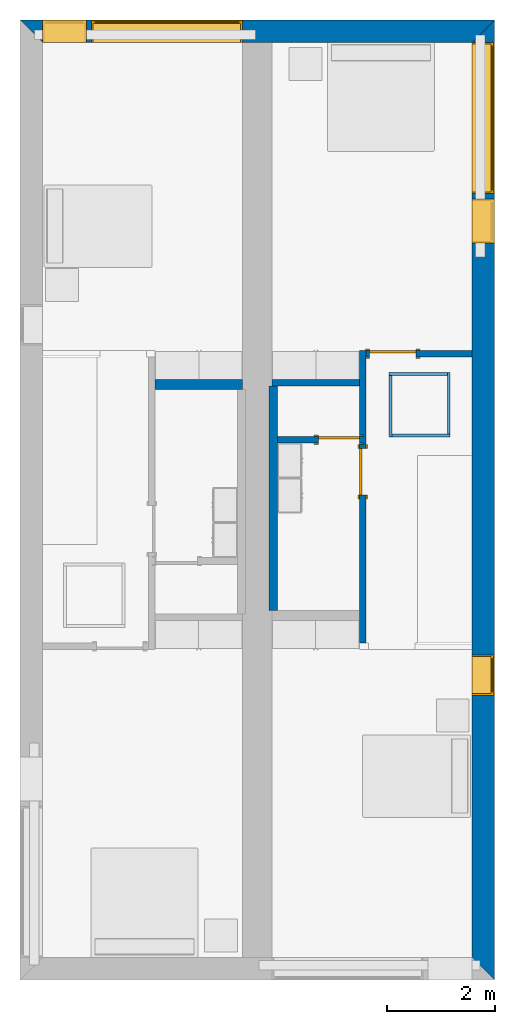
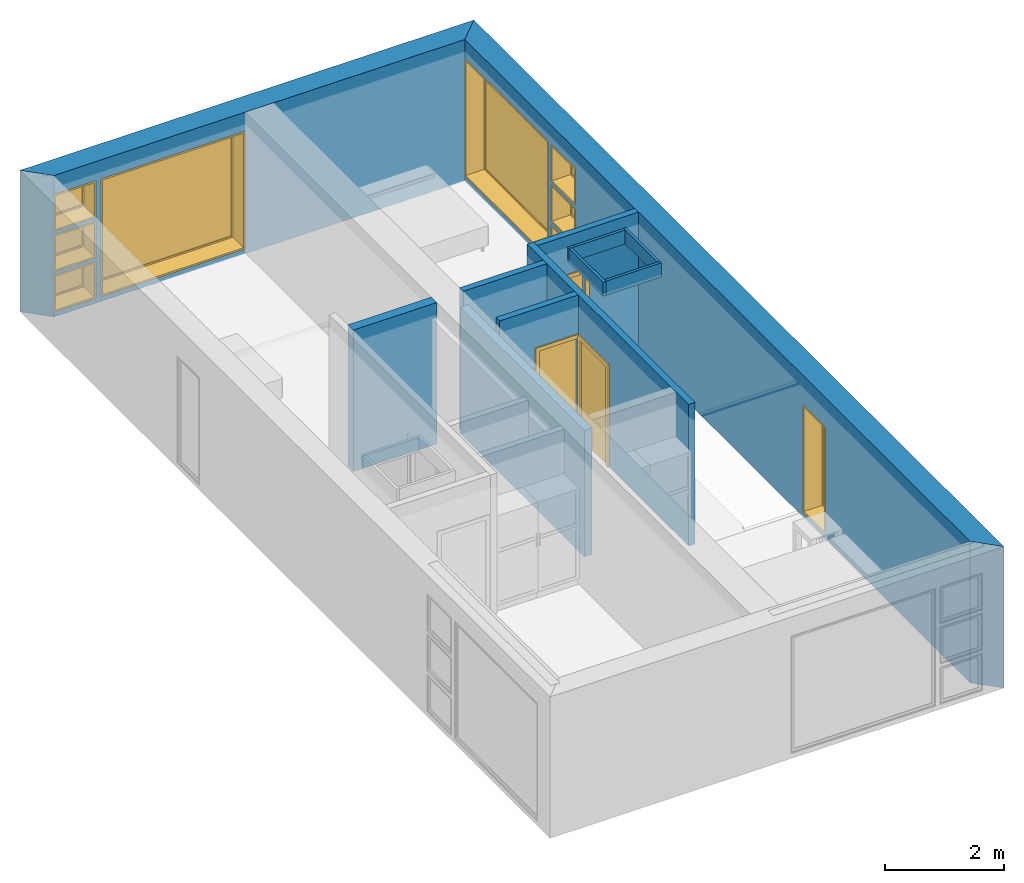
# One storey, part 3 of 12: 12 walls, 9 windows, 3 doors, 12 openings.
"""IFC2X3 building model written with IfcOpenShell, lengths in metres."""

from ifc_helpers import new_model, entity, si_unit, converted_unit, frame, frame_2d, origin, origin_2d_with_axis, place, context, project, spatial, polyline, rectangle, outline, extrude, source, transform, mapped, material, layer, layer_set, layer_usage, type_object, type_shapes, element, fill, save


model = new_model("IFC2X3")

# Units and contexts
model_context = context("Model", 3, precision=1e-09, world=origin())
plan_context = context("Plan", 3, precision=1e-09, world=origin())
ifc_project = project(units=[si_unit("LENGTHUNIT", "METRE"), si_unit("AREAUNIT", "SQUARE_METRE"), si_unit("VOLUMEUNIT", "CUBIC_METRE"), converted_unit("PLANEANGLEUNIT", "DEGREE", entity("IfcRatioMeasure", 0.0174532925199433), si_unit("PLANEANGLEUNIT", "RADIAN"), dimensions=[0, 0, 0, 0, 0, 0, 0]), si_unit("TIMEUNIT", "SECOND")], contexts=[model_context, plan_context])

# Site, building, storey
site_placement = place(None, origin())
site = spatial("IfcSite", under=ifc_project, at=site_placement, CompositionType="ELEMENT")
building_placement = place(site_placement, origin())
building = spatial("IfcBuilding", under=site, at=building_placement, CompositionType="ELEMENT")
storey_placement = place(building_placement, frame((0.0, 0.0, 3.10000000000038)))
storey = spatial("IfcBuildingStorey", under=building, at=storey_placement, Name="Level 2", CompositionType="ELEMENT", Elevation=3.10000000000038)

# Wall, openings, windows
ifc_material_1 = material(Name="Masonry - Brick")
ifc_layer_1 = layer(ifc_material_1, 0.092)
ifc_material_2 = material(Name="Misc. Air Layers - Air Space")
ifc_layer_2 = layer(ifc_material_2, 0.025)
ifc_material_3 = material(Name="Insulation / Thermal Barriers - Rigid insulation")
ifc_layer_3 = layer(ifc_material_3, 0.05)
ifc_material_4 = material(Name="Masonry - Concrete Block")
ifc_layer_4 = layer(ifc_material_4, 0.193)
ifc_material_5 = material(Name="Metal - Stud Layer")
ifc_layer_5 = layer(ifc_material_5, 0.041)
ifc_material_6 = material(Name="Plasterboard")
ifc_layer_6 = layer(ifc_material_6, 0.016)
ifc_layer_set_1 = layer_set([ifc_layer_1, ifc_layer_2, ifc_layer_3, ifc_layer_4, ifc_layer_5, ifc_layer_6], Name="Basic Wall:Exterior - Brick on Block")
ifc_layer_usage_1 = layer_usage(ifc_layer_set_1, "AXIS2", "NEGATIVE", 0.2085)
wall_1_placement = place(storey_placement, frame((0.0, -0.2085, 0.0)))
wall_1 = element("IfcWallStandardCase", 1, at=wall_1_placement, inside=storey, material=ifc_layer_usage_1, Name="Basic Wall:Exterior - Brick on Block", ObjectType="Basic Wall:Exterior - Brick on Block", context=model_context, shape_type="SweptSolid", body=[
    extrude(outline(polyline([(8.383, -0.2085), (8.8, 0.2085), (0.0, 0.2085), (0.417000000000001, -0.2085), (4.125, -0.2085), (4.675, -0.2085), (8.383, -0.2085)])), origin(), (0.0, 0.0, 1.0), 2.90000000000001),
])
opening_1_placement = place(wall_1_placement, frame((1.325, -0.2085, 0.0999999999998186)))
opening_1 = element("IfcOpeningElement", 2, at=opening_1_placement, cuts=wall_1, ObjectType="Opening", context=model_context, shape_type="SweptSolid", body=[
    extrude(rectangle(XDim=2.41, YDim=2.8, at=frame_2d((1.205, 1.4), x_axis=(1.0, 0.0))), frame((0.0, 0.0, 0.0), z_axis=(0.0, 1.0, 0.0), x_axis=(0.0, 0.0, 1.0)), (0.0, 0.0, 1.0), 0.417),
])
opening_2_placement = place(wall_1_placement, frame((0.417, -0.2085, 0.0999999999998235)))
opening_2 = element("IfcOpeningElement", 3, at=opening_2_placement, cuts=wall_1, ObjectType="Opening", context=model_context, shape_type="SweptSolid", body=[
    extrude(rectangle(XDim=0.758999999999998, YDim=0.819, at=frame_2d((0.379499999999999, 0.4095), x_axis=(1.0, 0.0))), frame((0.0, 0.0, 0.0), z_axis=(0.0, 1.0, 0.0), x_axis=(0.0, 0.0, 1.0)), (0.0, 0.0, 1.0), 0.417),
])
opening_3_placement = place(wall_1_placement, frame((0.417000000000015, -0.208500000000001, 0.925499999999817)))
opening_3 = element("IfcOpeningElement", 4, at=opening_3_placement, cuts=wall_1, ObjectType="Opening", context=model_context, shape_type="SweptSolid", body=[
    extrude(rectangle(XDim=0.759000000000001, YDim=0.819, at=frame_2d((0.3795, 0.4095), x_axis=(-1.0, 0.0))), frame((0.0, 0.0, 0.0), z_axis=(0.0, 1.0, 0.0), x_axis=(0.0, 0.0, 1.0)), (0.0, 0.0, 1.0), 0.417),
])
opening_4_placement = place(wall_1_placement, frame((0.417, -0.2085, 1.75099999999982)))
opening_4 = element("IfcOpeningElement", 5, at=opening_4_placement, cuts=wall_1, ObjectType="Opening", context=model_context, shape_type="SweptSolid", body=[
    extrude(rectangle(XDim=0.758999999999998, YDim=0.819, at=frame_2d((0.379499999999999, 0.4095), x_axis=(1.0, 0.0))), frame((0.0, 0.0, 0.0), z_axis=(0.0, 1.0, 0.0), x_axis=(0.0, 0.0, 1.0)), (0.0, 0.0, 1.0), 0.417),
])
window_style_1 = type_object("IfcWindowStyle", Name="2800mm x 2410mm", ConstructionType="NOTDEFINED", OperationType="NOTDEFINED", ParameterTakesPrecedence=False, Sizeable=False)
shared_shape_1 = source(origin(), model_context, "Body", "SweptSolid", [
    extrude(rectangle(XDim=0.012, YDim=2.674, at=origin_2d_with_axis()), frame((1.40000000000001, 0.375999999999996, 0.0629999999999851), z_axis=(0.0, 0.0, 1.0), x_axis=(0.0, -1.0, 0.0)), (0.0, 0.0, 1.0), 2.28400000000001),
    extrude(outline(polyline([(-1.381, -1.186), (1.381, -1.186), (1.381, 1.186), (-1.381, 1.186), (-1.381, -1.186)]), holes=[polyline([(-1.337, -1.142), (-1.337, 1.142), (1.337, 1.142), (1.337, -1.142), (-1.337, -1.142)])]), frame((1.40000000000001, 0.353999999999968, 1.20499999999999), z_axis=(0.0, 1.0, 0.0), x_axis=(1.0, 0.0, 0.0)), (0.0, 0.0, 1.0), 0.0440000000000274),
    extrude(outline(polyline([(-1.4, -1.205), (1.4, -1.205), (1.4, 1.205), (-1.4, 1.205), (-1.4, -1.205)]), holes=[polyline([(-1.381, -1.18599999999998), (-1.381, 1.18600000000002), (1.381, 1.18600000000002), (1.381, -1.18599999999998), (-1.381, -1.18599999999998)])]), frame((1.40000000000001, 0.353999999999968, 1.20500000000001), z_axis=(0.0, 1.0, 0.0), x_axis=(1.0, 0.0, 0.0)), (0.0, 0.0, 1.0), 0.0630000000000274),
    extrude(outline(polyline([(-1.4, -1.20499999999999), (1.4, -1.20499999999999), (1.4, 1.20499999999999), (-1.4, 1.20499999999999), (-1.4, -1.20499999999999)]), holes=[polyline([(-1.368, -1.17299999999998), (-1.368, 1.17300000000002), (1.368, 1.17300000000002), (1.368, -1.17299999999998), (-1.368, -1.17299999999998)])]), frame((1.40000000000001, 0.0, 1.20500000000001), z_axis=(0.0, 1.0, 0.0), x_axis=(1.0, 0.0, 0.0)), (0.0, 0.0, 1.0), 0.353999999999973),
])
type_shapes(window_style_1, [shared_shape_1])
window_1_placement = place(opening_1_placement, origin())
window_1 = element("IfcWindow", 6, at=window_1_placement, inside=storey, type_object=window_style_1, ObjectType="2800mm x 2410mm", OverallHeight=2.41, OverallWidth=2.8, context=model_context, shape_type="MappedRepresentation", body=[
    mapped(shared_shape_1, transform((0.0, 0.0, 0.0), scale=1.0)),
])
fill(opening_1, window_1)
window_style_2 = type_object("IfcWindowStyle", Name="819mm x 759mm", ConstructionType="NOTDEFINED", OperationType="NOTDEFINED", ParameterTakesPrecedence=False, Sizeable=False)
shared_shape_2 = source(origin(), model_context, "Body", "SweptSolid", [
    extrude(rectangle(XDim=0.012, YDim=0.692999999999997, at=origin_2d_with_axis()), frame((0.409500000000007, 0.375999999999999, 0.0629999999999851), z_axis=(0.0, 0.0, 1.0), x_axis=(0.0, -1.0, 0.0)), (0.0, 0.0, 1.0), 0.633000000000007),
    extrude(outline(polyline([(-0.3905, -0.360500000000003), (0.3905, -0.360500000000003), (0.3905, 0.360500000000003), (-0.3905, 0.360500000000003), (-0.3905, -0.360500000000003)]), holes=[polyline([(-0.3465, -0.316500000000003), (-0.3465, 0.316500000000004), (0.346499999999997, 0.316500000000004), (0.346499999999997, -0.316500000000003), (-0.3465, -0.316500000000003)])]), frame((0.409500000000008, 0.353999999999971, 0.379499999999989), z_axis=(0.0, 1.0, 0.0), x_axis=(1.0, 0.0, 0.0)), (0.0, 0.0, 1.0), 0.0440000000000274),
    extrude(outline(polyline([(-0.4095, -0.379499999999997), (0.4095, -0.379499999999997), (0.4095, 0.379499999999997), (-0.4095, 0.379499999999997), (-0.4095, -0.379499999999997)]), holes=[polyline([(-0.390500000000001, -0.360499999999982), (-0.390500000000001, 0.360500000000023), (0.390499999999999, 0.360500000000023), (0.390499999999999, -0.360499999999982), (-0.390500000000001, -0.360499999999982)])]), frame((0.409500000000009, 0.353999999999971, 0.37950000000001), z_axis=(0.0, 1.0, 0.0), x_axis=(1.0, 0.0, 0.0)), (0.0, 0.0, 1.0), 0.0630000000000274),
    extrude(outline(polyline([(-0.4095, -0.379499999999997), (0.4095, -0.379499999999997), (0.4095, 0.379499999999997), (-0.4095, 0.379499999999997), (-0.4095, -0.379499999999997)]), holes=[polyline([(-0.3775, -0.347499999999983), (-0.3775, 0.347500000000021), (0.3775, 0.347500000000021), (0.3775, -0.347499999999983), (-0.3775, -0.347499999999983)])]), frame((0.40950000000001, 0.0, 0.379500000000009), z_axis=(0.0, 1.0, 0.0), x_axis=(1.0, 0.0, 0.0)), (0.0, 0.0, 1.0), 0.353999999999973),
])
type_shapes(window_style_2, [shared_shape_2])
window_2_placement = place(opening_2_placement, origin())
window_2 = element("IfcWindow", 7, at=window_2_placement, inside=storey, type_object=window_style_2, ObjectType="819mm x 759mm", OverallHeight=0.758999999999998, OverallWidth=0.819, context=model_context, shape_type="MappedRepresentation", body=[
    mapped(shared_shape_2, transform((0.0, 0.0, 0.0), scale=1.0)),
])
fill(opening_2, window_2)
window_3_placement = place(opening_4_placement, origin())
window_3 = element("IfcWindow", 8, at=window_3_placement, inside=storey, type_object=window_style_2, ObjectType="819mm x 759mm", OverallHeight=0.758999999999999, OverallWidth=0.819, context=model_context, shape_type="MappedRepresentation", body=[
    mapped(shared_shape_2, transform((0.0, 0.0, 0.0), scale=1.0)),
])
fill(opening_4, window_3)
window_style_3 = type_object("IfcWindowStyle", Name="819mm x 759mm", ConstructionType="NOTDEFINED", OperationType="NOTDEFINED", ParameterTakesPrecedence=False, Sizeable=False)
shared_shape_3 = source(origin(), model_context, "Body", "SweptSolid", [
    extrude(rectangle(XDim=0.0127, YDim=0.691999999999998, at=origin_2d_with_axis()), frame((0.4095, 0.375775, 0.063500000000004), z_axis=(0.0, 0.0, 1.0), x_axis=(0.0, 1.0, 0.0)), (0.0, 0.0, 1.0), 0.632000000000004),
    extrude(outline(polyline([(-0.390449999999999, -0.360450000000001), (0.390449999999999, -0.360450000000001), (0.390449999999999, 0.360450000000001), (-0.390449999999999, 0.360450000000001), (-0.390449999999999, -0.360450000000001)]), holes=[polyline([(-0.345999999999998, -0.316000000000002), (-0.345999999999998, 0.316000000000003), (0.346, 0.316000000000003), (0.346, -0.316000000000002), (-0.345999999999998, -0.316000000000002)])]), frame((0.409499999999999, 0.35355, 0.379500000000007), z_axis=(0.0, 1.0, 0.0), x_axis=(1.0, 0.0, 0.0)), (0.0, 0.0, 1.0), 0.04445),
    extrude(outline(polyline([(-0.409499999999999, -0.379500000000001), (0.409499999999999, -0.379500000000001), (0.409499999999999, 0.379500000000001), (-0.409499999999999, 0.379500000000001), (-0.409499999999999, -0.379500000000001)]), holes=[polyline([(-0.37775, -0.34775), (-0.37775, 0.347750000000001), (0.377749999999998, 0.347750000000001), (0.377749999999998, -0.34775), (-0.37775, -0.34775)])]), frame((0.409500000000001, 0.0, 0.379500000000008), z_axis=(0.0, 1.0, 0.0), x_axis=(1.0, 0.0, 0.0)), (0.0, 0.0, 1.0), 0.35355),
    extrude(outline(polyline([(-0.379500000000002, -0.409499999999999), (0.379500000000002, -0.409499999999999), (0.379500000000002, 0.409499999999999), (-0.379500000000002, 0.409499999999999), (-0.379500000000002, -0.409499999999999)]), holes=[polyline([(-0.360450000000002, -0.390449999999999), (-0.360450000000002, 0.39045), (0.360450000000002, 0.39045), (0.360450000000002, -0.390449999999999), (-0.360450000000002, -0.390449999999999)])]), frame((0.4095, 0.35355, 0.379500000000007), z_axis=(0.0, 1.0, 0.0), x_axis=(0.0, 0.0, -1.0)), (0.0, 0.0, 1.0), 0.06345),
])
type_shapes(window_style_3, [shared_shape_3])
window_4_placement = place(opening_3_placement, origin())
window_4 = element("IfcWindow", 9, at=window_4_placement, inside=storey, type_object=window_style_3, ObjectType="819mm x 759mm", OverallHeight=0.759000000000001, OverallWidth=0.819, context=model_context, shape_type="MappedRepresentation", body=[
    mapped(shared_shape_3, transform((0.0, 0.0, 0.0), scale=1.0)),
])
fill(opening_3, window_4)

ifc_layer_usage_2 = layer_usage(ifc_layer_set_1, "AXIS2", "NEGATIVE", 0.2085)
wall_2_placement = place(storey_placement, frame((8.5915, 0.0, 0.0), z_axis=(0.0, 0.0, 1.0), x_axis=(0.0, -1.0, 0.0)))
wall_2 = element("IfcWallStandardCase", 10, at=wall_2_placement, inside=storey, material=ifc_layer_usage_2, Name="Basic Wall:Exterior - Brick on Block", ObjectType="Basic Wall:Exterior - Brick on Block", context=model_context, shape_type="SweptSolid", body=[
    extrude(outline(polyline([(17.383, -0.2085), (17.8, 0.2085), (0.0, 0.2085), (0.416999999999999, -0.208500000000001), (6.12599999999998, -0.2085), (6.24999999999998, -0.2085), (17.383, -0.2085)])), origin(), (0.0, 0.0, 1.0), 2.90000000000001),
])
opening_5_placement = place(wall_2_placement, frame((0.417000000000027, -0.208499999999995, 0.0999999999998186)))
opening_5 = element("IfcOpeningElement", 11, at=opening_5_placement, cuts=wall_2, ObjectType="Opening", context=model_context, shape_type="SweptSolid", body=[
    extrude(rectangle(XDim=2.41, YDim=2.8, at=frame_2d((1.205, 1.4), x_axis=(1.0, 0.0))), frame((0.0, 0.0, 0.0), z_axis=(0.0, 1.0, 0.0), x_axis=(0.0, 0.0, 1.0)), (0.0, 0.0, 1.0), 0.417),
])
opening_6_placement = place(wall_2_placement, frame((3.31700000000003, -0.208500000000004, 1.75099999999982)))
opening_6 = element("IfcOpeningElement", 12, at=opening_6_placement, cuts=wall_2, ObjectType="Opening", context=model_context, shape_type="SweptSolid", body=[
    extrude(rectangle(XDim=0.758999999999998, YDim=0.819, at=frame_2d((0.379499999999999, 0.4095), x_axis=(1.0, 0.0))), frame((0.0, 0.0, 0.0), z_axis=(0.0, 1.0, 0.0), x_axis=(0.0, 0.0, 1.0)), (0.0, 0.0, 1.0), 0.417),
])
opening_7_placement = place(wall_2_placement, frame((3.31700000000004, -0.208500000000005, 0.925499999999818)))
opening_7 = element("IfcOpeningElement", 13, at=opening_7_placement, cuts=wall_2, ObjectType="Opening", context=model_context, shape_type="SweptSolid", body=[
    extrude(rectangle(XDim=0.759000000000001, YDim=0.819, at=frame_2d((0.3795, 0.4095), x_axis=(-1.0, 0.0))), frame((0.0, 0.0, 0.0), z_axis=(0.0, 1.0, 0.0), x_axis=(0.0, 0.0, 1.0)), (0.0, 0.0, 1.0), 0.417),
])
opening_8_placement = place(wall_2_placement, frame((3.31700000000003, -0.208500000000004, 0.0999999999998186)))
opening_8 = element("IfcOpeningElement", 14, at=opening_8_placement, cuts=wall_2, ObjectType="Opening", context=model_context, shape_type="SweptSolid", body=[
    extrude(rectangle(XDim=0.758999999999998, YDim=0.819, at=frame_2d((0.379499999999999, 0.4095), x_axis=(1.0, 0.0))), frame((0.0, 0.0, 0.0), z_axis=(0.0, 1.0, 0.0), x_axis=(0.0, 0.0, 1.0)), (0.0, 0.0, 1.0), 0.417),
])
opening_9_placement = place(wall_2_placement, frame((11.774, -0.208500000000017, 0.0999999999998186)))
opening_9 = element("IfcOpeningElement", 15, at=opening_9_placement, cuts=wall_2, ObjectType="Opening", context=model_context, shape_type="SweptSolid", body=[
    extrude(rectangle(XDim=2.2, YDim=0.75, at=frame_2d((1.1, 0.374999999999999), x_axis=(1.0, 0.0))), frame((0.0, 0.0, 0.0), z_axis=(0.0, 1.0, 0.0), x_axis=(0.0, 0.0, 1.0)), (0.0, 0.0, 1.0), 0.417),
])
window_style_4 = type_object("IfcWindowStyle", Name="750mm x 2200mm", ConstructionType="NOTDEFINED", OperationType="NOTDEFINED", ParameterTakesPrecedence=False, Sizeable=False)
shared_shape_4 = source(origin(), model_context, "Body", "SweptSolid", [
    extrude(rectangle(XDim=0.012, YDim=0.623999999999997, at=origin_2d_with_axis()), frame((0.375000000000007, 0.375999999999999, 0.0629999999999851), z_axis=(0.0, 0.0, 1.0), x_axis=(0.0, -1.0, 0.0)), (0.0, 0.0, 1.0), 2.07400000000001),
    extrude(outline(polyline([(-0.356, -1.081), (0.356, -1.081), (0.356, 1.081), (-0.356, 1.081), (-0.356, -1.081)]), holes=[polyline([(-0.312, -1.037), (-0.312, 1.037), (0.311999999999998, 1.037), (0.311999999999998, -1.037), (-0.312, -1.037)])]), frame((0.375000000000008, 0.353999999999972, 1.09999999999999), z_axis=(0.0, 1.0, 0.0), x_axis=(1.0, 0.0, 0.0)), (0.0, 0.0, 1.0), 0.0440000000000274),
    extrude(outline(polyline([(-0.375, -1.1), (0.375, -1.1), (0.375, 1.1), (-0.375, 1.1), (-0.375, -1.1)]), holes=[polyline([(-0.356000000000001, -1.08099999999998), (-0.356000000000001, 1.08100000000002), (0.355999999999998, 1.08100000000002), (0.355999999999999, -1.08099999999998), (-0.356000000000001, -1.08099999999998)])]), frame((0.375000000000009, 0.353999999999972, 1.10000000000001), z_axis=(0.0, 1.0, 0.0), x_axis=(1.0, 0.0, 0.0)), (0.0, 0.0, 1.0), 0.0630000000000274),
    extrude(outline(polyline([(-0.375, -1.1), (0.375, -1.1), (0.375, 1.1), (-0.375, 1.1), (-0.375, -1.1)]), holes=[polyline([(-0.343, -1.06799999999998), (-0.343, 1.06800000000002), (0.343, 1.06800000000002), (0.343, -1.06799999999998), (-0.343, -1.06799999999998)])]), frame((0.37500000000001, 0.0, 1.10000000000001), z_axis=(0.0, 1.0, 0.0), x_axis=(1.0, 0.0, 0.0)), (0.0, 0.0, 1.0), 0.353999999999973),
])
type_shapes(window_style_4, [shared_shape_4])
window_5_placement = place(opening_9_placement, origin())
window_5 = element("IfcWindow", 16, at=window_5_placement, inside=storey, type_object=window_style_4, ObjectType="750mm x 2200mm", OverallHeight=2.2, OverallWidth=0.749999999999998, context=model_context, shape_type="MappedRepresentation", body=[
    mapped(shared_shape_4, transform((0.0, 0.0, 0.0), scale=1.0)),
])
fill(opening_9, window_5)
window_6_placement = place(opening_5_placement, origin())
window_6 = element("IfcWindow", 17, at=window_6_placement, inside=storey, type_object=window_style_1, ObjectType="2800mm x 2410mm", OverallHeight=2.41, OverallWidth=2.8, context=model_context, shape_type="MappedRepresentation", body=[
    mapped(shared_shape_1, transform((0.0, 0.0, 0.0), scale=1.0)),
])
fill(opening_5, window_6)
window_7_placement = place(opening_6_placement, origin())
window_7 = element("IfcWindow", 18, at=window_7_placement, inside=storey, type_object=window_style_2, ObjectType="819mm x 759mm", OverallHeight=0.758999999999998, OverallWidth=0.819, context=model_context, shape_type="MappedRepresentation", body=[
    mapped(shared_shape_2, transform((0.0, 0.0, 0.0), scale=1.0)),
])
fill(opening_6, window_7)
window_8_placement = place(opening_8_placement, origin())
window_8 = element("IfcWindow", 19, at=window_8_placement, inside=storey, type_object=window_style_2, ObjectType="819mm x 759mm", OverallHeight=0.758999999999999, OverallWidth=0.819, context=model_context, shape_type="MappedRepresentation", body=[
    mapped(shared_shape_2, transform((0.0, 0.0, 0.0), scale=1.0)),
])
fill(opening_8, window_8)
window_9_placement = place(opening_7_placement, origin())
window_9 = element("IfcWindow", 20, at=window_9_placement, inside=storey, type_object=window_style_3, ObjectType="819mm x 759mm", OverallHeight=0.759000000000001, OverallWidth=0.819, context=model_context, shape_type="MappedRepresentation", body=[
    mapped(shared_shape_3, transform((0.0, 0.0, 0.0), scale=1.0)),
])
fill(opening_7, window_9)

# Wall
ifc_layer_7 = layer(ifc_material_6, 0.016)
ifc_layer_8 = layer(ifc_material_5, 0.152)
ifc_layer_9 = layer(ifc_material_6, 0.016)
ifc_layer_set_2 = layer_set([ifc_layer_7, ifc_layer_8, ifc_layer_9], Name="Basic Wall:Interior - Plumbing (152mm Stud)")
ifc_layer_usage_3 = layer_usage(ifc_layer_set_2, "AXIS2", "NEGATIVE", 0.092)
wall_3_placement = place(storey_placement, frame((2.506, -6.758, 0.0)))
element("IfcWallStandardCase", 21, at=wall_3_placement, inside=storey, material=ifc_layer_usage_3, Name="Basic Wall:Interior - Plumbing (152mm Stud)", ObjectType="Basic Wall:Interior - Plumbing (152mm Stud)", context=model_context, shape_type="SweptSolid", body=[
    extrude(rectangle(XDim=1.61899999999999, YDim=0.183999999999999, at=frame_2d((0.809499999999996, 0.0), x_axis=(-1.0, 0.0))), origin(), (0.0, 0.0, 1.0), 2.90000000000001),
])

# Wall, opening, door
ifc_layer_10 = layer(ifc_material_6, 0.016)
ifc_layer_11 = layer(ifc_material_5, 0.092)
ifc_layer_12 = layer(ifc_material_6, 0.016)
ifc_layer_set_3 = layer_set([ifc_layer_10, ifc_layer_11, ifc_layer_12], Name="Basic Wall:Interior - Partition (92mm Stud)")
ifc_layer_usage_4 = layer_usage(ifc_layer_set_3, "AXIS2", "NEGATIVE", 0.062)
wall_4_placement = place(storey_placement, frame((6.356, -11.55, 0.0), z_axis=(0.0, 0.0, 1.0), x_axis=(0.0, 1.0, 0.0)))
wall_4 = element("IfcWallStandardCase", 22, at=wall_4_placement, inside=storey, material=ifc_layer_usage_4, Name="Basic Wall:Interior - Partition (92mm Stud)", ObjectType="Basic Wall:Interior - Partition (92mm Stud)", context=model_context, shape_type="SweptSolid", body=[
    extrude(rectangle(XDim=5.424, YDim=0.124, at=frame_2d((2.712, 0.0), x_axis=(-1.0, 0.0))), origin(), (0.0, 0.0, 1.0), 2.90000000000001),
])
opening_10_placement = place(wall_4_placement, frame((2.74061576492847, -0.0620000000000056, 0.0)))
opening_10 = element("IfcOpeningElement", 23, at=opening_10_placement, cuts=wall_4, Name="M_Single-Flush:0864 x 2032mm:0864 x 2032mm:1", ObjectType="Opening", context=model_context, shape_type="SweptSolid", body=[
    extrude(rectangle(XDim=0.863999999999999, YDim=2.032, at=frame_2d((1.016, 0.432), x_axis=(0.0, 1.0))), frame((0.0, 0.0, 0.0), z_axis=(0.0, 1.0, 0.0), x_axis=(0.0, 0.0, 1.0)), (0.0, 0.0, 1.0), 0.124),
])
door_style_1 = type_object("IfcDoorStyle", Name="0864 x 2032mm", ConstructionType="NOTDEFINED", OperationType="SINGLE_SWING_RIGHT", ParameterTakesPrecedence=False, Sizeable=False)
shared_shape_5 = source(origin(), model_context, "Body", "SweptSolid", [
    extrude(outline(polyline([(-0.508, -1.073), (0.508, -1.073), (0.508, 1.035), (0.432, 1.035), (0.432, -0.997000000000002), (-0.432, -0.997000000000002), (-0.432, 1.035), (-0.508, 1.035), (-0.508, -1.073)])), frame((0.432000000000001, 0.123999999999999, 1.035), z_axis=(0.0, 1.0, 0.0), x_axis=(1.0, 0.0, 0.0)), (0.0, 0.0, 1.0), 0.0249999999999944),
    extrude(outline(polyline([(-1.073, -0.507999999999997), (1.035, -0.507999999999997), (1.035, -0.432000000000007), (-0.997, -0.432000000000007), (-0.997, 0.432000000000002), (1.035, 0.432000000000002), (1.035, 0.508000000000003), (-1.073, 0.508000000000003), (-1.073, -0.507999999999997)])), frame((0.432000000000003, -0.0250000000000064, 1.035), z_axis=(0.0, 1.0, 0.0), x_axis=(0.0, 0.0, -1.0)), (0.0, 0.0, 1.0), 0.0250000000000056),
    extrude(rectangle(XDim=0.051, YDim=0.864, at=origin_2d_with_axis()), frame((0.432, 0.0984999999999992, 0.0), z_axis=(0.0, 0.0, 1.0), x_axis=(0.0, 1.0, 0.0)), (0.0, 0.0, 1.0), 2.032),
])
type_shapes(door_style_1, [shared_shape_5])
door_1_placement = place(opening_10_placement, origin())
door_1 = element("IfcDoor", 24, at=door_1_placement, inside=storey, type_object=door_style_1, Name="M_Single-Flush:0864 x 2032mm:0864 x 2032mm", ObjectType="0864 x 2032mm", OverallHeight=2.032, OverallWidth=0.864, context=model_context, shape_type="MappedRepresentation", body=[
    mapped(shared_shape_5, transform((0.0, 0.0, 0.0), scale=1.0)),
])
fill(opening_10, door_1)

ifc_layer_usage_5 = layer_usage(ifc_layer_set_3, "AXIS2", "NEGATIVE", 0.062)
wall_5_placement = place(storey_placement, frame((6.41800000000001, -6.188, 0.0)))
wall_5 = element("IfcWallStandardCase", 25, at=wall_5_placement, inside=storey, material=ifc_layer_usage_5, Name="Basic Wall:Interior - Partition (92mm Stud)", ObjectType="Basic Wall:Interior - Partition (92mm Stud)", context=model_context, shape_type="SweptSolid", body=[
    extrude(rectangle(XDim=1.96499999999998, YDim=0.124, at=frame_2d((0.982499999999991, 0.0), x_axis=(-1.0, 0.0))), origin(), (0.0, 0.0, 1.0), 2.90000000000001),
])
opening_11_placement = place(wall_5_placement, frame((0.0600000000000002, -0.0620000000000021, 0.0)))
opening_11 = element("IfcOpeningElement", 26, at=opening_11_placement, cuts=wall_5, Name="M_Single-Flush:0864 x 2032mm:0864 x 2032mm:1", ObjectType="Opening", context=model_context, shape_type="SweptSolid", body=[
    extrude(rectangle(XDim=0.864, YDim=2.032, at=frame_2d((1.016, 0.432), x_axis=(0.0, -1.0))), frame((0.0, 0.0, 0.0), z_axis=(0.0, 1.0, 0.0), x_axis=(0.0, 0.0, 1.0)), (0.0, 0.0, 1.0), 0.124),
])
door_style_2 = type_object("IfcDoorStyle", Name="0864 x 2032mm", ConstructionType="NOTDEFINED", OperationType="SINGLE_SWING_LEFT", ParameterTakesPrecedence=False, Sizeable=False)
shared_shape_6 = source(origin(), model_context, "Body", "SweptSolid", [
    extrude(outline(polyline([(-0.508, -1.073), (0.508, -1.073), (0.508, 1.035), (0.432, 1.035), (0.432, -0.997000000000002), (-0.432, -0.997000000000002), (-0.432, 1.035), (-0.508, 1.035), (-0.508, -1.073)])), frame((0.432, 0.148999999999988, 1.035), z_axis=(0.0, -1.0, 0.0), x_axis=(-1.0, 0.0, 0.0)), (0.0, 0.0, 1.0), 0.0249999999999944),
    extrude(outline(polyline([(-1.073, -0.507999999999997), (1.035, -0.507999999999997), (1.035, -0.432000000000007), (-0.997, -0.432000000000007), (-0.997, 0.432000000000002), (1.035, 0.432000000000002), (1.035, 0.508000000000003), (-1.073, 0.508000000000003), (-1.073, -0.507999999999997)])), frame((0.431999999999998, 0.0, 1.035), z_axis=(0.0, -1.0, 0.0), x_axis=(0.0, 0.0, -1.0)), (0.0, 0.0, 1.0), 0.0250000000000056),
    extrude(rectangle(XDim=0.864, YDim=0.051, at=origin_2d_with_axis()), frame((0.432, 0.0984999999999937, 0.0)), (0.0, 0.0, 1.0), 2.032),
])
type_shapes(door_style_2, [shared_shape_6])
door_2_placement = place(opening_11_placement, origin())
door_2 = element("IfcDoor", 27, at=door_2_placement, inside=storey, type_object=door_style_2, Name="M_Single-Flush:0864 x 2032mm:0864 x 2032mm", ObjectType="0864 x 2032mm", OverallHeight=2.032, OverallWidth=0.864, context=model_context, shape_type="MappedRepresentation", body=[
    mapped(shared_shape_6, transform((0.0, 0.0, 0.0), scale=1.0)),
])
fill(opening_11, door_2)

# Walls
ifc_layer_usage_6 = layer_usage(ifc_layer_set_3, "AXIS2", "NEGATIVE", 0.062)
wall_6_placement = place(storey_placement, frame((4.67499999999999, -6.728, 0.0)))
element("IfcWallStandardCase", 28, at=wall_6_placement, inside=storey, material=ifc_layer_usage_6, Name="Basic Wall:Interior - Partition (92mm Stud)", ObjectType="Basic Wall:Interior - Partition (92mm Stud)", context=model_context, shape_type="SweptSolid", body=[
    extrude(rectangle(XDim=1.61900000000002, YDim=0.124, at=frame_2d((0.809500000000009, 0.0), x_axis=(-1.0, 0.0))), origin(), (0.0, 0.0, 1.0), 2.90000000000001),
])
ifc_layer_13 = layer(ifc_material_5, 0.136)
ifc_layer_14 = layer(ifc_material_6, 0.016)
ifc_layer_set_4 = layer_set([ifc_layer_13, ifc_layer_14], Name="Basic Wall:Interior - Furring (152 mm Stud)")
ifc_layer_usage_7 = layer_usage(ifc_layer_set_4, "AXIS2", "POSITIVE", -0.076)
wall_7_placement = place(storey_placement, frame((4.69399999999999, -6.79, 0.0), z_axis=(0.0, 0.0, 1.0), x_axis=(0.0, -1.0, 0.0)))
element("IfcWallStandardCase", 29, at=wall_7_placement, inside=storey, material=ifc_layer_usage_7, Name="Basic Wall:Interior - Furring (152 mm Stud)", ObjectType="Basic Wall:Interior - Furring (152 mm Stud)", context=model_context, shape_type="SweptSolid", body=[
    extrude(rectangle(XDim=4.16000000000001, YDim=0.152, at=frame_2d((2.08, 0.0), x_axis=(-1.0, 0.0))), origin(), (0.0, 0.0, 1.0), 2.59500000000001),
])

# Wall, opening, door
ifc_layer_usage_8 = layer_usage(ifc_layer_set_3, "AXIS2", "POSITIVE", -0.062)
wall_8_placement = place(storey_placement, frame((4.76999999999999, -7.78338423507152, 0.0)))
wall_8 = element("IfcWallStandardCase", 30, at=wall_8_placement, inside=storey, material=ifc_layer_usage_8, Name="Basic Wall:Interior - Partition (92mm Stud)", ObjectType="Basic Wall:Interior - Partition (92mm Stud)", context=model_context, shape_type="SweptSolid", body=[
    extrude(rectangle(XDim=1.52400000000002, YDim=0.124, at=frame_2d((0.762000000000009, 0.0), x_axis=(-1.0, 0.0))), origin(), (0.0, 0.0, 1.0), 2.90000000000001),
])
opening_12_placement = place(wall_8_placement, frame((0.761375000000016, -0.0620000000000032, 0.0)))
opening_12 = element("IfcOpeningElement", 31, at=opening_12_placement, cuts=wall_8, Name="M_Single-Flush:0762 x 2032mm:0762 x 2032mm:1", ObjectType="Opening", context=model_context, shape_type="SweptSolid", body=[
    extrude(rectangle(XDim=0.762, YDim=2.032, at=frame_2d((1.016, 0.381), x_axis=(0.0, 1.0))), frame((0.0, 0.0, 0.0), z_axis=(0.0, 1.0, 0.0), x_axis=(0.0, 0.0, 1.0)), (0.0, 0.0, 1.0), 0.124),
])
door_style_3 = type_object("IfcDoorStyle", Name="0762 x 2032mm", ConstructionType="NOTDEFINED", OperationType="SINGLE_SWING_RIGHT", ParameterTakesPrecedence=False, Sizeable=False)
shared_shape_7 = source(origin(), model_context, "Body", "SweptSolid", [
    extrude(outline(polyline([(-0.457, -1.073), (0.457, -1.073), (0.457, 1.035), (0.381, 1.035), (0.381, -0.997000000000002), (-0.381, -0.997000000000002), (-0.381, 1.035), (-0.457, 1.035), (-0.457, -1.073)])), frame((0.381000000000001, 0.123999999999999, 1.035), z_axis=(0.0, 1.0, 0.0), x_axis=(1.0, 0.0, 0.0)), (0.0, 0.0, 1.0), 0.0249999999999945),
    extrude(outline(polyline([(-1.073, -0.456999999999997), (1.035, -0.456999999999997), (1.035, -0.381000000000007), (-0.997, -0.381000000000007), (-0.997, 0.381000000000002), (1.035, 0.381000000000002), (1.035, 0.457000000000003), (-1.073, 0.457000000000003), (-1.073, -0.456999999999997)])), frame((0.381000000000003, -0.0250000000000063, 1.035), z_axis=(0.0, 1.0, 0.0), x_axis=(0.0, 0.0, -1.0)), (0.0, 0.0, 1.0), 0.0250000000000056),
    extrude(rectangle(XDim=0.051, YDim=0.762, at=origin_2d_with_axis()), frame((0.381000000000001, 0.0984999999999993, 0.0), z_axis=(0.0, 0.0, 1.0), x_axis=(0.0, 1.0, 0.0)), (0.0, 0.0, 1.0), 2.032),
])
type_shapes(door_style_3, [shared_shape_7])
door_3_placement = place(opening_12_placement, origin())
door_3 = element("IfcDoor", 32, at=door_3_placement, inside=storey, type_object=door_style_3, Name="M_Single-Flush:0762 x 2032mm:0762 x 2032mm", ObjectType="0762 x 2032mm", OverallHeight=2.032, OverallWidth=0.762, context=model_context, shape_type="MappedRepresentation", body=[
    mapped(shared_shape_7, transform((0.0, 0.0, 0.0), scale=1.0)),
])
fill(opening_12, door_3)

# Walls
ifc_layer_15 = layer(ifc_material_5, 0.038)
ifc_layer_16 = layer(ifc_material_6, 0.016)
ifc_layer_set_5 = layer_set([ifc_layer_15, ifc_layer_16], Name="Basic Wall:Interior - Furring (38 mm Stud)")
ifc_layer_usage_9 = layer_usage(ifc_layer_set_5, "AXIS2", "NEGATIVE", 0.027)
wall_9_placement = place(storey_placement, frame((6.84045000000003, -6.56745000000005, 2.612)))
element("IfcWallStandardCase", 33, at=wall_9_placement, inside=storey, material=ifc_layer_usage_9, Name="Basic Wall:Interior - Furring (38 mm Stud)", ObjectType="Basic Wall:Interior - Furring (38 mm Stud)", context=model_context, shape_type="SweptSolid", body=[
    extrude(rectangle(XDim=1.0831, YDim=0.0540000000000007, at=frame_2d((0.54155, 0.0), x_axis=(-1.0, 0.0))), origin(), (0.0, 0.0, 1.0), 0.288000000000013),
])
ifc_layer_usage_10 = layer_usage(ifc_layer_set_5, "AXIS2", "NEGATIVE", 0.027)
wall_10_placement = place(storey_placement, frame((6.86745000000003, -7.72955000000001, 2.612), z_axis=(0.0, 0.0, 1.0), x_axis=(0.0, 1.0, 0.0)))
element("IfcWallStandardCase", 34, at=wall_10_placement, inside=storey, material=ifc_layer_usage_10, Name="Basic Wall:Interior - Furring (38 mm Stud)", ObjectType="Basic Wall:Interior - Furring (38 mm Stud)", context=model_context, shape_type="SweptSolid", body=[
    extrude(rectangle(XDim=1.13509999999996, YDim=0.0540000000000007, at=frame_2d((0.567549999999979, 0.0), x_axis=(-1.0, 0.0))), origin(), (0.0, 0.0, 1.0), 0.288000000000013),
])
ifc_layer_usage_11 = layer_usage(ifc_layer_set_5, "AXIS2", "NEGATIVE", 0.027)
wall_11_placement = place(storey_placement, frame((7.97755000000003, -7.70255000000001, 2.612), z_axis=(0.0, 0.0, 1.0), x_axis=(-1.0, 0.0, 0.0)))
element("IfcWallStandardCase", 35, at=wall_11_placement, inside=storey, material=ifc_layer_usage_11, Name="Basic Wall:Interior - Furring (38 mm Stud)", ObjectType="Basic Wall:Interior - Furring (38 mm Stud)", context=model_context, shape_type="SweptSolid", body=[
    extrude(rectangle(XDim=1.0831, YDim=0.0540000000000007, at=frame_2d((0.54155, 0.0), x_axis=(-1.0, 0.0))), origin(), (0.0, 0.0, 1.0), 0.288000000000013),
])
ifc_layer_usage_12 = layer_usage(ifc_layer_set_5, "AXIS2", "NEGATIVE", 0.027)
wall_12_placement = place(storey_placement, frame((7.95055000000003, -6.54045000000005, 2.612), z_axis=(0.0, 0.0, 1.0), x_axis=(0.0, -1.0, 0.0)))
element("IfcWallStandardCase", 36, at=wall_12_placement, inside=storey, material=ifc_layer_usage_12, Name="Basic Wall:Interior - Furring (38 mm Stud)", ObjectType="Basic Wall:Interior - Furring (38 mm Stud)", context=model_context, shape_type="SweptSolid", body=[
    extrude(rectangle(XDim=1.13509999999996, YDim=0.0540000000000007, at=frame_2d((0.56754999999998, 0.0), x_axis=(-1.0, 0.0))), origin(), (0.0, 0.0, 1.0), 0.288000000000013),
])

save(model, "model.ifc")
